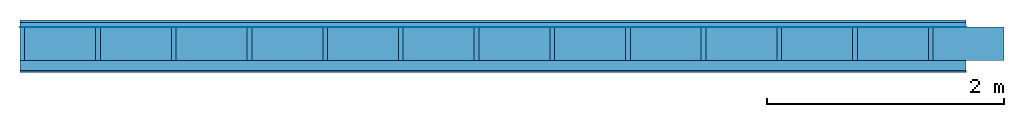
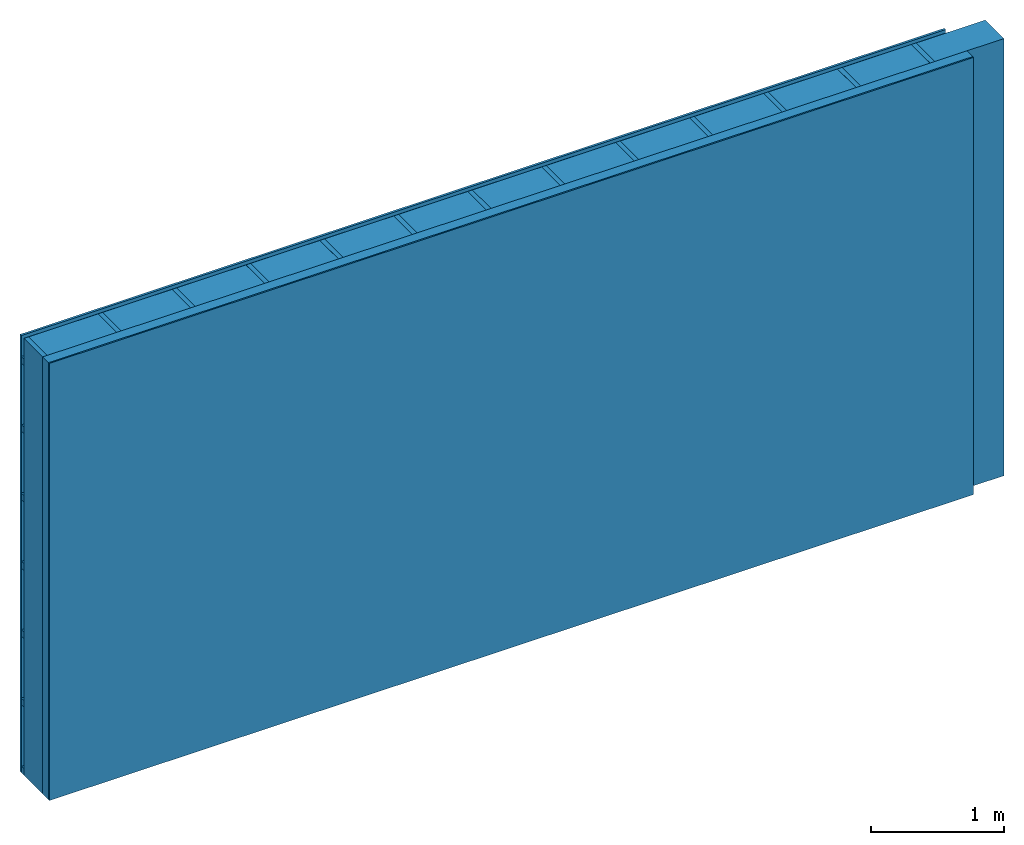
# One storey: 4 plates, 3 members, 1 element without a shape of its own.
"""IFC4 building model written with IfcOpenShell, lengths in metres."""

from ifc_helpers import new_model, si_unit, derived_unit, direction, frame, frame_2d, origin, origin_with_axes, place, context, project, spatial, rectangle, extrude, material, layer, layer_set, type_object, element, aggregate, save


model = new_model("IFC4")

# Units and contexts
plan_context = context("Plan", 3, precision=1e-05, world=origin(), true_north=direction((0.0, 1.0)))
model_context = context("Model", 3, precision=1e-05, world=origin(), true_north=direction((0.0, 1.0)))
ifc_project = project(units=[si_unit("LENGTHUNIT", "METRE"), derived_unit("SOUNDPRESSUREUNIT", [(si_unit("PRESSUREUNIT", "PASCAL", prefix="MICRO"), 0)]), si_unit("ENERGYUNIT", "JOULE", prefix="MEGA"), si_unit("MASSUNIT", "GRAM", prefix="KILO"), derived_unit("THERMALTRANSMITTANCEUNIT", [(si_unit("POWERUNIT", "WATT"), 1), (si_unit("AREAUNIT", "SQUARE_METRE"), -1), (si_unit("THERMODYNAMICTEMPERATUREUNIT", "KELVIN"), -1)]), derived_unit("AREADENSITYUNIT", [(si_unit("MASSUNIT", "GRAM", prefix="KILO"), 1), (si_unit("AREAUNIT", "SQUARE_METRE"), -1)]), derived_unit("USERDEFINED", [(si_unit("ENERGYUNIT", "JOULE", prefix="MEGA"), 1), (si_unit("AREAUNIT", "SQUARE_METRE"), -1)])], contexts=[plan_context, model_context])

# Site, building, storey
site = spatial("IfcSite", under=ifc_project)
building_placement = place(None, origin())
building = spatial("IfcBuilding", under=site, at=building_placement)
storey_placement = place(building_placement, origin())
storey = spatial("IfcBuildingStorey", under=building, at=storey_placement)

# Wall, members, plates
ifc_material_1 = material(Name="Wood cladding horizontal, closed")
ifc_layer_1 = layer(ifc_material_1, 0.02, Name="Cover 1st layer")
ifc_layer_2 = layer(None, 0.04, Name="Battens / profiles (ventilation)")
ifc_material_2 = material(Name="Vapor-permeable water barrier", Category="09.006")
ifc_layer_3 = layer(ifc_material_2, 0.0005, Name="outside 1st layer")
ifc_material_3 = material(Name="of the art")
ifc_layer_4 = layer(ifc_material_3, 0.0, Name="Bond")
ifc_layer_5 = layer(None, 0.28, Name="Support")
ifc_layer_6 = layer(ifc_material_3, 0.0, Name="Bond")
ifc_material_4 = material(Name="Solid timber panel")
ifc_layer_7 = layer(ifc_material_4, 0.087, Name="1st layer")
ifc_material_5 = material(Name="Plasterboard type A", Category="03.008")
ifc_layer_8 = layer(ifc_material_5, 0.0125, Name="Covering 1st layer")
ifc_material_6 = material(Name="joints", Category="04.017")
ifc_layer_9 = layer(ifc_material_6, 0.0, Name="Surface")
ifc_layer_set = layer_set([ifc_layer_1, ifc_layer_2, ifc_layer_3, ifc_layer_4, ifc_layer_5, ifc_layer_6, ifc_layer_7, ifc_layer_8, ifc_layer_9])
wall_type = type_object("IfcWallType", Name="D0987", PredefinedType="NOTDEFINED", material=ifc_layer_set)
wall_placement = place(None, frame((0.0, 0.0, 0.0), z_axis=(0.0, -1.0, 0.0), x_axis=(1.0, 0.0, 0.0)))
wall = element("IfcWall", 1, at=wall_placement, inside=storey, type_object=wall_type, material=ifc_layer_set, Name="Wall #1")
ifc_material_7 = material()
member_1_placement = place(wall_placement, origin())
member_1 = element("IfcMember", 2, at=member_1_placement, material=ifc_material_7, Name="Battens / profiles (ventilation)", context=plan_context, shape_type="SweptSolid", body=[
    extrude(rectangle(XDim=0.06, YDim=0.04, at=frame_2d((0.03, 0.02), x_axis=(1.0, 0.0))), frame((0.0, 0.0, 0.02), z_axis=(1.0, 0.0, 0.0), x_axis=(0.0, 1.0, 0.0)), (0.0, 0.0, 1.0), 8.0),
    extrude(rectangle(XDim=0.06, YDim=0.04, at=frame_2d((0.03, 0.02), x_axis=(1.0, 0.0))), frame((0.0, 0.625, 0.02), z_axis=(1.0, 0.0, 0.0), x_axis=(0.0, 1.0, 0.0)), (0.0, 0.0, 1.0), 8.0),
    extrude(rectangle(XDim=0.06, YDim=0.04, at=frame_2d((0.03, 0.02), x_axis=(1.0, 0.0))), frame((0.0, 1.25, 0.02), z_axis=(1.0, 0.0, 0.0), x_axis=(0.0, 1.0, 0.0)), (0.0, 0.0, 1.0), 8.0),
    extrude(rectangle(XDim=0.06, YDim=0.04, at=frame_2d((0.03, 0.02), x_axis=(1.0, 0.0))), frame((0.0, 1.875, 0.02), z_axis=(1.0, 0.0, 0.0), x_axis=(0.0, 1.0, 0.0)), (0.0, 0.0, 1.0), 8.0),
    extrude(rectangle(XDim=0.06, YDim=0.04, at=frame_2d((0.03, 0.02), x_axis=(1.0, 0.0))), frame((0.0, 2.5, 0.02), z_axis=(1.0, 0.0, 0.0), x_axis=(0.0, 1.0, 0.0)), (0.0, 0.0, 1.0), 8.0),
    extrude(rectangle(XDim=0.06, YDim=0.04, at=frame_2d((0.03, 0.02), x_axis=(1.0, 0.0))), frame((0.0, 3.125, 0.02), z_axis=(1.0, 0.0, 0.0), x_axis=(0.0, 1.0, 0.0)), (0.0, 0.0, 1.0), 8.0),
    extrude(rectangle(XDim=0.06, YDim=0.04, at=frame_2d((0.03, 0.02), x_axis=(1.0, 0.0))), frame((0.0, 3.75, 0.02), z_axis=(1.0, 0.0, 0.0), x_axis=(0.0, 1.0, 0.0)), (0.0, 0.0, 1.0), 8.0),
])
ifc_material_8 = material()
member_2_placement = place(wall_placement, origin())
member_2 = element("IfcMember", 3, at=member_2_placement, material=ifc_material_8, Name="Support", context=plan_context, shape_type="SweptSolid", body=[
    extrude(rectangle(XDim=0.04, YDim=0.28, at=frame_2d((0.02, 0.14), x_axis=(1.0, 0.0))), frame((0.0, 4.0, 0.0605), z_axis=(0.0, -1.0, 0.0), x_axis=(1.0, 0.0, 0.0)), (0.0, 0.0, 1.0), 4.0),
    extrude(rectangle(XDim=0.04, YDim=0.28, at=frame_2d((0.02, 0.14), x_axis=(1.0, 0.0))), frame((0.64, 4.0, 0.0605), z_axis=(0.0, -1.0, 0.0), x_axis=(1.0, 0.0, 0.0)), (0.0, 0.0, 1.0), 4.0),
    extrude(rectangle(XDim=0.04, YDim=0.28, at=frame_2d((0.02, 0.14), x_axis=(1.0, 0.0))), frame((1.28, 4.0, 0.0605), z_axis=(0.0, -1.0, 0.0), x_axis=(1.0, 0.0, 0.0)), (0.0, 0.0, 1.0), 4.0),
    extrude(rectangle(XDim=0.04, YDim=0.28, at=frame_2d((0.02, 0.14), x_axis=(1.0, 0.0))), frame((1.92, 4.0, 0.0605), z_axis=(0.0, -1.0, 0.0), x_axis=(1.0, 0.0, 0.0)), (0.0, 0.0, 1.0), 4.0),
    extrude(rectangle(XDim=0.04, YDim=0.28, at=frame_2d((0.02, 0.14), x_axis=(1.0, 0.0))), frame((2.56, 4.0, 0.0605), z_axis=(0.0, -1.0, 0.0), x_axis=(1.0, 0.0, 0.0)), (0.0, 0.0, 1.0), 4.0),
    extrude(rectangle(XDim=0.04, YDim=0.28, at=frame_2d((0.02, 0.14), x_axis=(1.0, 0.0))), frame((3.2, 4.0, 0.0605), z_axis=(0.0, -1.0, 0.0), x_axis=(1.0, 0.0, 0.0)), (0.0, 0.0, 1.0), 4.0),
    extrude(rectangle(XDim=0.04, YDim=0.28, at=frame_2d((0.02, 0.14), x_axis=(1.0, 0.0))), frame((3.84, 4.0, 0.0605), z_axis=(0.0, -1.0, 0.0), x_axis=(1.0, 0.0, 0.0)), (0.0, 0.0, 1.0), 4.0),
    extrude(rectangle(XDim=0.04, YDim=0.28, at=frame_2d((0.02, 0.14), x_axis=(1.0, 0.0))), frame((4.48, 4.0, 0.0605), z_axis=(0.0, -1.0, 0.0), x_axis=(1.0, 0.0, 0.0)), (0.0, 0.0, 1.0), 4.0),
    extrude(rectangle(XDim=0.04, YDim=0.28, at=frame_2d((0.02, 0.14), x_axis=(1.0, 0.0))), frame((5.12, 4.0, 0.0605), z_axis=(0.0, -1.0, 0.0), x_axis=(1.0, 0.0, 0.0)), (0.0, 0.0, 1.0), 4.0),
    extrude(rectangle(XDim=0.04, YDim=0.28, at=frame_2d((0.02, 0.14), x_axis=(1.0, 0.0))), frame((5.76, 4.0, 0.0605), z_axis=(0.0, -1.0, 0.0), x_axis=(1.0, 0.0, 0.0)), (0.0, 0.0, 1.0), 4.0),
    extrude(rectangle(XDim=0.04, YDim=0.28, at=frame_2d((0.02, 0.14), x_axis=(1.0, 0.0))), frame((6.4, 4.0, 0.0605), z_axis=(0.0, -1.0, 0.0), x_axis=(1.0, 0.0, 0.0)), (0.0, 0.0, 1.0), 4.0),
    extrude(rectangle(XDim=0.04, YDim=0.28, at=frame_2d((0.02, 0.14), x_axis=(1.0, 0.0))), frame((7.04, 4.0, 0.0605), z_axis=(0.0, -1.0, 0.0), x_axis=(1.0, 0.0, 0.0)), (0.0, 0.0, 1.0), 4.0),
    extrude(rectangle(XDim=0.04, YDim=0.28, at=frame_2d((0.02, 0.14), x_axis=(1.0, 0.0))), frame((7.68, 4.0, 0.0605), z_axis=(0.0, -1.0, 0.0), x_axis=(1.0, 0.0, 0.0)), (0.0, 0.0, 1.0), 4.0),
])
ifc_material_9 = material(Name="Mineral wool")
member_3_placement = place(wall_placement, origin())
member_3 = element("IfcMember", 4, at=member_3_placement, material=ifc_material_9, Name="Cavity", context=plan_context, shape_type="SweptSolid", body=[
    extrude(rectangle(XDim=0.6, YDim=0.28, at=frame_2d((0.3, 0.14), x_axis=(1.0, 0.0))), frame((0.04, 4.0, 0.0605), z_axis=(0.0, -1.0, 0.0), x_axis=(1.0, 0.0, 0.0)), (0.0, 0.0, 1.0), 4.0),
    extrude(rectangle(XDim=0.6, YDim=0.28, at=frame_2d((0.3, 0.14), x_axis=(1.0, 0.0))), frame((0.68, 4.0, 0.0605), z_axis=(0.0, -1.0, 0.0), x_axis=(1.0, 0.0, 0.0)), (0.0, 0.0, 1.0), 4.0),
    extrude(rectangle(XDim=0.6, YDim=0.28, at=frame_2d((0.3, 0.14), x_axis=(1.0, 0.0))), frame((1.32, 4.0, 0.0605), z_axis=(0.0, -1.0, 0.0), x_axis=(1.0, 0.0, 0.0)), (0.0, 0.0, 1.0), 4.0),
    extrude(rectangle(XDim=0.6, YDim=0.28, at=frame_2d((0.3, 0.14), x_axis=(1.0, 0.0))), frame((1.96, 4.0, 0.0605), z_axis=(0.0, -1.0, 0.0), x_axis=(1.0, 0.0, 0.0)), (0.0, 0.0, 1.0), 4.0),
    extrude(rectangle(XDim=0.6, YDim=0.28, at=frame_2d((0.3, 0.14), x_axis=(1.0, 0.0))), frame((2.6, 4.0, 0.0605), z_axis=(0.0, -1.0, 0.0), x_axis=(1.0, 0.0, 0.0)), (0.0, 0.0, 1.0), 4.0),
    extrude(rectangle(XDim=0.6, YDim=0.28, at=frame_2d((0.3, 0.14), x_axis=(1.0, 0.0))), frame((3.24, 4.0, 0.0605), z_axis=(0.0, -1.0, 0.0), x_axis=(1.0, 0.0, 0.0)), (0.0, 0.0, 1.0), 4.0),
    extrude(rectangle(XDim=0.6, YDim=0.28, at=frame_2d((0.3, 0.14), x_axis=(1.0, 0.0))), frame((3.88, 4.0, 0.0605), z_axis=(0.0, -1.0, 0.0), x_axis=(1.0, 0.0, 0.0)), (0.0, 0.0, 1.0), 4.0),
    extrude(rectangle(XDim=0.6, YDim=0.28, at=frame_2d((0.3, 0.14), x_axis=(1.0, 0.0))), frame((4.52, 4.0, 0.0605), z_axis=(0.0, -1.0, 0.0), x_axis=(1.0, 0.0, 0.0)), (0.0, 0.0, 1.0), 4.0),
    extrude(rectangle(XDim=0.6, YDim=0.28, at=frame_2d((0.3, 0.14), x_axis=(1.0, 0.0))), frame((5.16, 4.0, 0.0605), z_axis=(0.0, -1.0, 0.0), x_axis=(1.0, 0.0, 0.0)), (0.0, 0.0, 1.0), 4.0),
    extrude(rectangle(XDim=0.6, YDim=0.28, at=frame_2d((0.3, 0.14), x_axis=(1.0, 0.0))), frame((5.8, 4.0, 0.0605), z_axis=(0.0, -1.0, 0.0), x_axis=(1.0, 0.0, 0.0)), (0.0, 0.0, 1.0), 4.0),
    extrude(rectangle(XDim=0.6, YDim=0.28, at=frame_2d((0.3, 0.14), x_axis=(1.0, 0.0))), frame((6.44, 4.0, 0.0605), z_axis=(0.0, -1.0, 0.0), x_axis=(1.0, 0.0, 0.0)), (0.0, 0.0, 1.0), 4.0),
    extrude(rectangle(XDim=0.6, YDim=0.28, at=frame_2d((0.3, 0.14), x_axis=(1.0, 0.0))), frame((7.08, 4.0, 0.0605), z_axis=(0.0, -1.0, 0.0), x_axis=(1.0, 0.0, 0.0)), (0.0, 0.0, 1.0), 4.0),
    extrude(rectangle(XDim=0.6, YDim=0.28, at=frame_2d((0.3, 0.14), x_axis=(1.0, 0.0))), frame((7.72, 4.0, 0.0605), z_axis=(0.0, -1.0, 0.0), x_axis=(1.0, 0.0, 0.0)), (0.0, 0.0, 1.0), 4.0),
])
plate_1_placement = place(wall_placement, origin())
plate_1 = element("IfcPlate", 5, at=plate_1_placement, material=ifc_material_1, Name="Cover 1st layer", context=plan_context, shape_type="SweptSolid", body=[
    extrude(rectangle(XDim=8.0, YDim=4.0, at=frame_2d((4.0, 2.0), x_axis=(1.0, 0.0))), origin_with_axes(), (0.0, 0.0, 1.0), 0.02),
])
plate_2_placement = place(wall_placement, origin())
plate_2 = element("IfcPlate", 6, at=plate_2_placement, material=ifc_material_2, Name="outside 1st layer", context=plan_context, shape_type="SweptSolid", body=[
    extrude(rectangle(XDim=8.0, YDim=4.0, at=frame_2d((4.0, 2.0), x_axis=(1.0, 0.0))), frame((0.0, 0.0, 0.06), z_axis=(0.0, 0.0, 1.0), x_axis=(1.0, 0.0, 0.0)), (0.0, 0.0, 1.0), 0.0005),
])
plate_3_placement = place(wall_placement, origin())
plate_3 = element("IfcPlate", 7, at=plate_3_placement, material=ifc_material_4, Name="1st layer", context=plan_context, shape_type="SweptSolid", body=[
    extrude(rectangle(XDim=8.0, YDim=4.0, at=frame_2d((4.0, 2.0), x_axis=(1.0, 0.0))), frame((0.0, 0.0, 0.3405), z_axis=(0.0, 0.0, 1.0), x_axis=(1.0, 0.0, 0.0)), (0.0, 0.0, 1.0), 0.087),
])
plate_4_placement = place(wall_placement, origin())
plate_4 = element("IfcPlate", 8, at=plate_4_placement, material=ifc_material_5, Name="Covering 1st layer", context=plan_context, shape_type="SweptSolid", body=[
    extrude(rectangle(XDim=8.0, YDim=4.0, at=frame_2d((4.0, 2.0), x_axis=(1.0, 0.0))), frame((0.0, 0.0, 0.4275), z_axis=(0.0, 0.0, 1.0), x_axis=(1.0, 0.0, 0.0)), (0.0, 0.0, 1.0), 0.0125),
])
aggregate(wall, [plate_1, member_1, plate_2, member_2, member_3, plate_3, plate_4])

save(model, "model.ifc")
